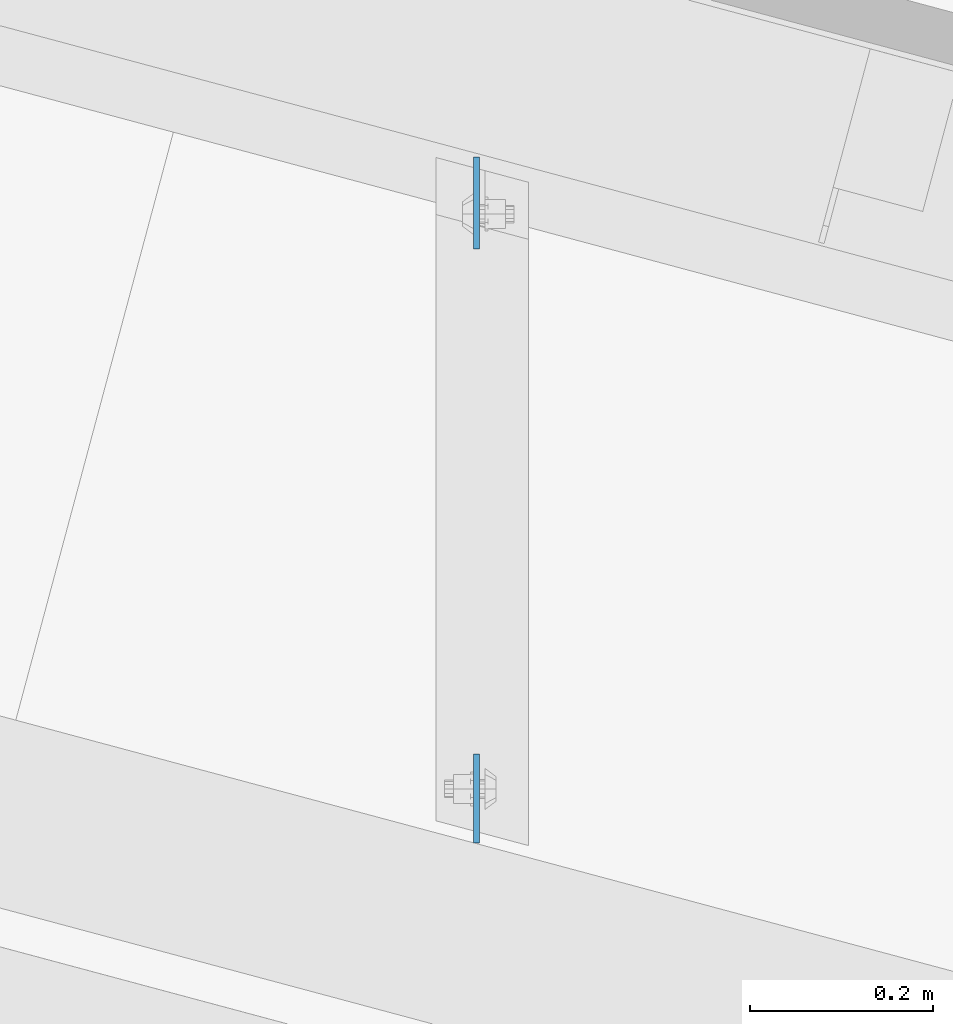
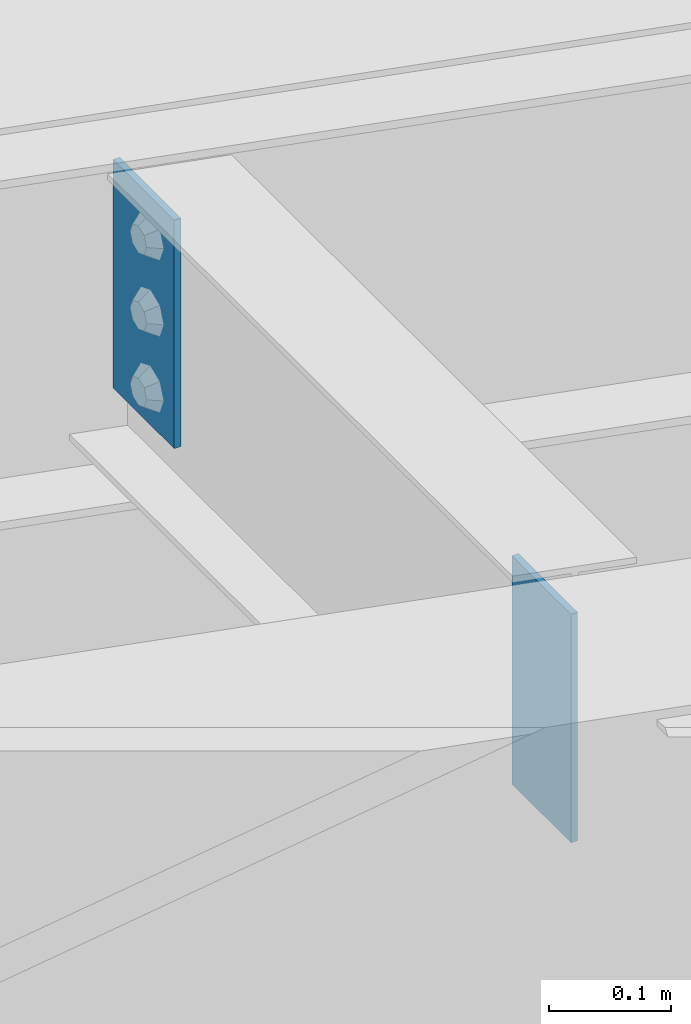
# One storey, part 1691 of 1763: 2 plates, 2 elements without a shape of their own.
"""IFC2X3 building model written with IfcOpenShell, lengths in millimetres."""

from ifc_helpers import new_model, si_unit, frame, origin_with_axes, place, context, subcontext, project, spatial, faceted_brep, material, type_object, element, aggregate, save


model = new_model("IFC2X3")

# Units and contexts
model_context = context("Model", 3, precision=1e-05, world=origin_with_axes())
body_context = subcontext(model_context, "Body", "Model", "MODEL_VIEW")
ifc_project = project(units=[si_unit("LENGTHUNIT", "METRE", prefix="MILLI"), si_unit("AREAUNIT", "SQUARE_METRE"), si_unit("VOLUMEUNIT", "CUBIC_METRE"), si_unit("MASSUNIT", "GRAM", prefix="KILO"), si_unit("TIMEUNIT", "SECOND"), si_unit("PLANEANGLEUNIT", "RADIAN"), si_unit("SOLIDANGLEUNIT", "STERADIAN"), si_unit("THERMODYNAMICTEMPERATUREUNIT", "DEGREE_CELSIUS"), si_unit("LUMINOUSINTENSITYUNIT", "LUMEN")], contexts=[model_context])

# Site, building, storey
site_placement = place(None, origin_with_axes())
site = spatial("IfcSite", under=ifc_project, at=site_placement, CompositionType="ELEMENT")
building_placement = place(site_placement, origin_with_axes())
building = spatial("IfcBuilding", under=site, at=building_placement, Name="Undefined", CompositionType="ELEMENT")
storey_placement = place(building_placement, origin_with_axes())
storey = spatial("IfcBuildingStorey", under=building, at=storey_placement, Name="Undefined", CompositionType="ELEMENT", Elevation=0.0)

# Assembly, plate
assembly_1_placement = place(storey_placement, origin_with_axes())
assembly_1 = element("IfcElementAssembly", 1, at=assembly_1_placement, inside=storey, Name="BEAM", AssemblyPlace="NOTDEFINED", PredefinedType="RIGID_FRAME")
ifc_material = material(Name="STEEL/A36")
plate_type_1 = type_object("IfcPlateType", PredefinedType="NOTDEFINED")
plate_1_placement = place(assembly_1_placement, frame((-29406.8796174532, 64036.8290495405, 12407.9), z_axis=(0.0, 1.0, 0.0), x_axis=(0.0, 0.0, -1.0)))
plate_1 = element("IfcPlate", 2, at=plate_1_placement, type_object=plate_type_1, material=ifc_material, Name="PLATE", context=body_context, shape_type="Brep", body=[
    faceted_brep([(1.81898940354586e-12, -3.17500000000291, 0.0), (0.0, -3.17499999999927, 97.1715316772461), (0.0, 3.17499999999927, 97.1715316772461), (-1.81898940354586e-12, 3.17499999997381, 0.0), (228.600006103516, -3.17499999999927, 97.1715316772461), (228.600006103516, 3.17499999999927, 97.1715316772461), (228.600006103516, -3.17500000001019, -7.27595761418343e-12), (228.600006103516, 3.17499999999563, -7.27595761418343e-12)], [[[0, 1, 2, 3]], [[1, 4, 5, 2]], [[4, 6, 7, 5]], [[6, 0, 3, 7]], [[5, 7, 3, 2]], [[6, 4, 1, 0]]]),
])
aggregate(assembly_1, [plate_1])

assembly_2_placement = place(storey_placement, origin_with_axes())
assembly_2 = element("IfcElementAssembly", 3, at=assembly_2_placement, inside=storey, Name="BEAM", AssemblyPlace="NOTDEFINED", PredefinedType="RIGID_FRAME")
plate_type_2 = type_object("IfcPlateType", PredefinedType="NOTDEFINED")
plate_2_placement = place(assembly_2_placement, frame((-29406.8796174515, 64787.9456428838, 12407.9), z_axis=(0.0, -1.0, 0.0), x_axis=(0.0, 0.0, -1.0)))
plate_2 = element("IfcPlate", 4, at=plate_2_placement, type_object=plate_type_2, material=ifc_material, Name="PLATE", context=body_context, shape_type="Brep", body=[
    faceted_brep([(1.81898940354586e-12, -3.17500000000291, 0.0), (0.0, -3.17499999982829, 100.460510253775), (0.0, 3.17500000019209, 100.460510253775), (-1.81898940354586e-12, 3.17499999997381, 0.0), (228.600006103516, -3.17499999982829, 100.460510253775), (228.600006103516, 3.17500000019209, 100.460510253775), (228.600006103516, -3.17500000001019, -7.27595761418343e-12), (228.600006103516, 3.17499999999563, -7.27595761418343e-12)], [[[0, 1, 2, 3]], [[1, 4, 5, 2]], [[4, 6, 7, 5]], [[6, 0, 3, 7]], [[5, 7, 3, 2]], [[6, 4, 1, 0]]]),
])
aggregate(assembly_2, [plate_2])

save(model, "model.ifc")
